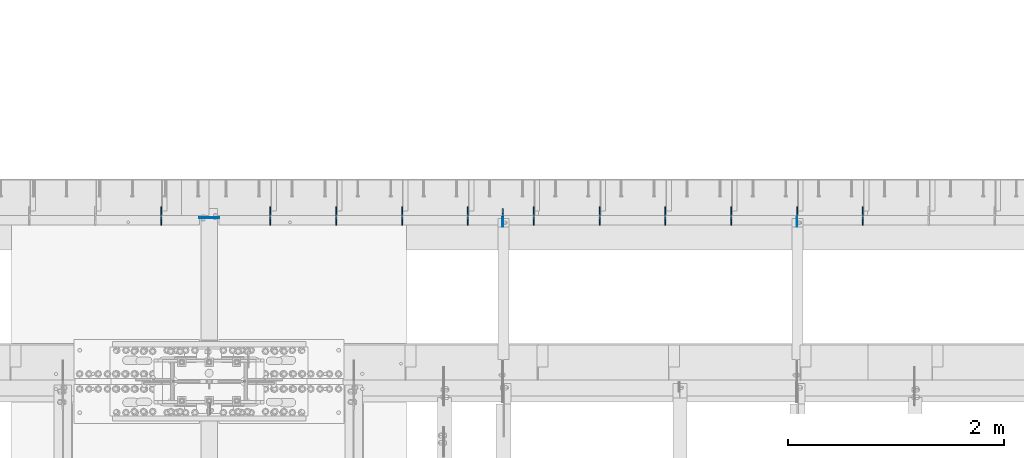
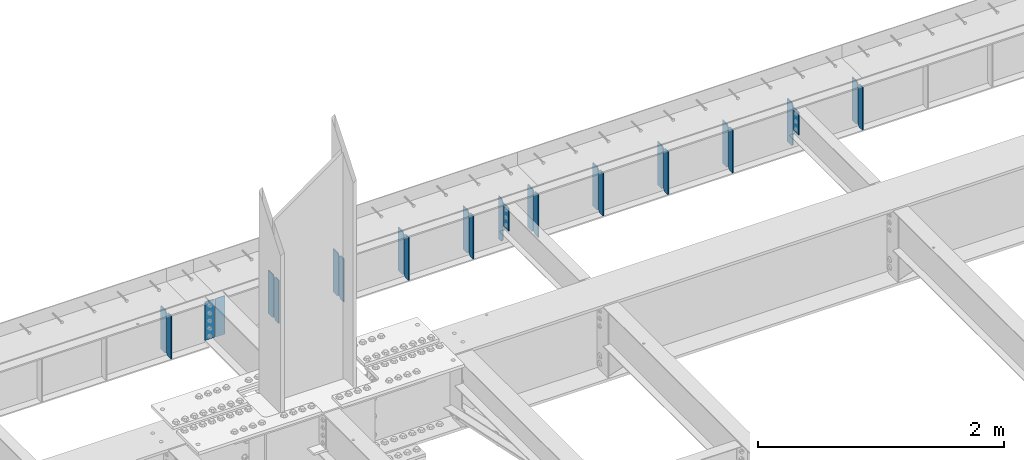
# One storey, part 1612 of 1763: 26 plates, 3 elements without a shape of their own.
"""IFC2X3 building model written with IfcOpenShell, lengths in millimetres."""

from ifc_helpers import new_model, si_unit, frame, origin_with_axes, place, context, subcontext, project, spatial, faceted_brep, material, type_object, element, aggregate, save


model = new_model("IFC2X3")

# Units and contexts
model_context = context("Model", 3, precision=1e-05, world=origin_with_axes())
body_context = subcontext(model_context, "Body", "Model", "MODEL_VIEW")
ifc_project = project(units=[si_unit("LENGTHUNIT", "METRE", prefix="MILLI"), si_unit("AREAUNIT", "SQUARE_METRE"), si_unit("VOLUMEUNIT", "CUBIC_METRE"), si_unit("MASSUNIT", "GRAM", prefix="KILO"), si_unit("TIMEUNIT", "SECOND"), si_unit("PLANEANGLEUNIT", "RADIAN"), si_unit("SOLIDANGLEUNIT", "STERADIAN"), si_unit("THERMODYNAMICTEMPERATUREUNIT", "DEGREE_CELSIUS"), si_unit("LUMINOUSINTENSITYUNIT", "LUMEN")], contexts=[model_context])

# Site, building, storey
site_placement = place(None, origin_with_axes())
site = spatial("IfcSite", under=ifc_project, at=site_placement, CompositionType="ELEMENT")
building_placement = place(site_placement, origin_with_axes())
building = spatial("IfcBuilding", under=site, at=building_placement, Name="Undefined", CompositionType="ELEMENT")
storey_placement = place(building_placement, origin_with_axes())
storey = spatial("IfcBuildingStorey", under=building, at=storey_placement, Name="Undefined", CompositionType="ELEMENT", Elevation=0.0)

# Assembly, plates
assembly_1_placement = place(storey_placement, origin_with_axes())
assembly_1 = element("IfcElementAssembly", 1, at=assembly_1_placement, inside=storey, Name="BEAM", AssemblyPlace="NOTDEFINED", PredefinedType="RIGID_FRAME")
ifc_material = material(Name="STEEL/A36")
plate_type_1 = type_object("IfcPlateType", PredefinedType="NOTDEFINED")
plate_1_placement = place(assembly_1_placement, frame((-66437.8997736984, 53568.6, 4752.975), z_axis=(0.0, 0.0, 1.0), x_axis=(0.0, 1.0, 0.0)))
plate_1 = element("IfcPlate", 2, at=plate_1_placement, type_object=plate_type_1, material=ifc_material, Name="PLATE", context=body_context, shape_type="Brep", body=[
    faceted_brep([(0.0, -4.76249999999982, 0.0), (0.0, -4.76249999999709, 428.625), (0.0, 4.76249999999709, 428.625), (0.0, 4.76249999999982, 0.0), (53.1812477111816, -4.76249999999709, 428.625), (53.1812477111816, 4.76249999999709, 428.625), (72.2312469482422, -4.76249999999709, 409.575000762939), (72.2312469482422, 4.76249999999709, 409.575000762939), (72.2312469482422, -4.76249999999709, 19.0499992370605), (72.2312469482422, 4.76249999999709, 19.0499992370605), (53.1812477111816, -4.76249999999709, 0.0), (53.1812477111816, 4.76249999999709, 0.0)], [[[0, 1, 2, 3]], [[1, 4, 5, 2]], [[4, 6, 7, 5]], [[6, 8, 9, 7]], [[8, 10, 11, 9]], [[10, 0, 3, 11]], [[5, 7, 9, 11, 3, 2]], [[10, 8, 6, 4, 1, 0]]]),
])
plate_2_placement = place(assembly_1_placement, frame((-67657.0997736984, 53568.6, 4752.975), z_axis=(0.0, 0.0, 1.0), x_axis=(0.0, 1.0, 0.0)))
plate_2 = element("IfcPlate", 3, at=plate_2_placement, type_object=plate_type_1, material=ifc_material, Name="PLATE", context=body_context, shape_type="Brep", body=[
    faceted_brep([(0.0, -4.76249999999982, 0.0), (0.0, -4.76249999999709, 428.625), (0.0, 4.76249999999709, 428.625), (0.0, 4.76249999999982, 0.0), (53.1812477111816, -4.76249999999709, 428.625), (53.1812477111816, 4.76249999999709, 428.625), (72.2312469482422, -4.76249999999709, 409.575000762939), (72.2312469482422, 4.76249999999709, 409.575000762939), (72.2312469482422, -4.76249999999709, 19.0499992370605), (72.2312469482422, 4.76249999999709, 19.0499992370605), (53.1812477111816, -4.76249999999709, 0.0), (53.1812477111816, 4.76249999999709, 0.0)], [[[0, 1, 2, 3]], [[1, 4, 5, 2]], [[4, 6, 7, 5]], [[6, 8, 9, 7]], [[8, 10, 11, 9]], [[10, 0, 3, 11]], [[5, 7, 9, 11, 3, 2]], [[10, 8, 6, 4, 1, 0]]]),
])
plate_3_placement = place(assembly_1_placement, frame((-68266.6997736983, 53568.6, 4752.975), z_axis=(0.0, 0.0, 1.0), x_axis=(0.0, 1.0, 0.0)))
plate_3 = element("IfcPlate", 4, at=plate_3_placement, type_object=plate_type_1, material=ifc_material, Name="PLATE", context=body_context, shape_type="Brep", body=[
    faceted_brep([(0.0, -4.76249999999982, 0.0), (0.0, -4.76249999999709, 428.625), (0.0, 4.76249999999709, 428.625), (0.0, 4.76249999999982, 0.0), (53.1812477111816, -4.76249999999709, 428.625), (53.1812477111816, 4.76249999999709, 428.625), (72.2312469482422, -4.76249999999709, 409.575000762939), (72.2312469482422, 4.76249999999709, 409.575000762939), (72.2312469482422, -4.76249999999709, 19.0499992370605), (72.2312469482422, 4.76249999999709, 19.0499992370605), (53.1812477111816, -4.76249999999709, 0.0), (53.1812477111816, 4.76249999999709, 0.0)], [[[0, 1, 2, 3]], [[1, 4, 5, 2]], [[4, 6, 7, 5]], [[6, 8, 9, 7]], [[8, 10, 11, 9]], [[10, 0, 3, 11]], [[5, 7, 9, 11, 3, 2]], [[10, 8, 6, 4, 1, 0]]]),
])
plate_4_placement = place(assembly_1_placement, frame((-68876.2997736984, 53568.6, 4752.975), z_axis=(0.0, 0.0, 1.0), x_axis=(0.0, 1.0, 0.0)))
plate_4 = element("IfcPlate", 5, at=plate_4_placement, type_object=plate_type_1, material=ifc_material, Name="PLATE", context=body_context, shape_type="Brep", body=[
    faceted_brep([(0.0, -4.76249999999982, 0.0), (0.0, -4.76249999999709, 428.625), (0.0, 4.76249999999709, 428.625), (0.0, 4.76249999999982, 0.0), (53.1812477111816, -4.76249999999709, 428.625), (53.1812477111816, 4.76249999999709, 428.625), (72.2312469482422, -4.76249999999709, 409.575000762939), (72.2312469482422, 4.76249999999709, 409.575000762939), (72.2312469482422, -4.76249999999709, 19.0499992370605), (72.2312469482422, 4.76249999999709, 19.0499992370605), (53.1812477111816, -4.76249999999709, 0.0), (53.1812477111816, 4.76249999999709, 0.0)], [[[0, 1, 2, 3]], [[1, 4, 5, 2]], [[4, 6, 7, 5]], [[6, 8, 9, 7]], [[8, 10, 11, 9]], [[10, 0, 3, 11]], [[5, 7, 9, 11, 3, 2]], [[10, 8, 6, 4, 1, 0]]]),
])
plate_5_placement = place(assembly_1_placement, frame((-69485.8997736984, 53568.6, 4752.975), z_axis=(0.0, 0.0, 1.0), x_axis=(0.0, 1.0, 0.0)))
plate_5 = element("IfcPlate", 6, at=plate_5_placement, type_object=plate_type_1, material=ifc_material, Name="PLATE", context=body_context, shape_type="Brep", body=[
    faceted_brep([(0.0, -4.76249999999982, 0.0), (0.0, -4.76249999999709, 428.625), (0.0, 4.76249999999709, 428.625), (0.0, 4.76249999999982, 0.0), (53.1812477111816, -4.76249999999709, 428.625), (53.1812477111816, 4.76249999999709, 428.625), (72.2312469482422, -4.76249999999709, 409.575000762939), (72.2312469482422, 4.76249999999709, 409.575000762939), (72.2312469482422, -4.76249999999709, 19.0499992370605), (72.2312469482422, 4.76249999999709, 19.0499992370605), (53.1812477111816, -4.76249999999709, 0.0), (53.1812477111816, 4.76249999999709, 0.0)], [[[0, 1, 2, 3]], [[1, 4, 5, 2]], [[4, 6, 7, 5]], [[6, 8, 9, 7]], [[8, 10, 11, 9]], [[10, 0, 3, 11]], [[5, 7, 9, 11, 3, 2]], [[10, 8, 6, 4, 1, 0]]]),
])
plate_6_placement = place(assembly_1_placement, frame((-70095.4997736983, 53568.6, 4752.975), z_axis=(0.0, 0.0, 1.0), x_axis=(0.0, 1.0, 0.0)))
plate_6 = element("IfcPlate", 7, at=plate_6_placement, type_object=plate_type_1, material=ifc_material, Name="PLATE", context=body_context, shape_type="Brep", body=[
    faceted_brep([(0.0, -4.76249999999982, 0.0), (0.0, -4.76249999999709, 428.625), (0.0, 4.76249999999709, 428.625), (0.0, 4.76249999999982, 0.0), (53.1812477111816, -4.76249999999709, 428.625), (53.1812477111816, 4.76249999999709, 428.625), (72.2312469482422, -4.76249999999709, 409.575000762939), (72.2312469482422, 4.76249999999709, 409.575000762939), (72.2312469482422, -4.76249999999709, 19.0499992370605), (72.2312469482422, 4.76249999999709, 19.0499992370605), (53.1812477111816, -4.76249999999709, 0.0), (53.1812477111816, 4.76249999999709, 0.0)], [[[0, 1, 2, 3]], [[1, 4, 5, 2]], [[4, 6, 7, 5]], [[6, 8, 9, 7]], [[8, 10, 11, 9]], [[10, 0, 3, 11]], [[5, 7, 9, 11, 3, 2]], [[10, 8, 6, 4, 1, 0]]]),
])
plate_7_placement = place(assembly_1_placement, frame((-70705.0997736984, 53568.6, 4752.975), z_axis=(0.0, 0.0, 1.0), x_axis=(0.0, 1.0, 0.0)))
plate_7 = element("IfcPlate", 8, at=plate_7_placement, type_object=plate_type_1, material=ifc_material, Name="PLATE", context=body_context, shape_type="Brep", body=[
    faceted_brep([(0.0, -4.76249999999982, 0.0), (0.0, -4.76249999999709, 428.625), (0.0, 4.76249999999709, 428.625), (0.0, 4.76249999999982, 0.0), (53.1812477111816, -4.76249999999709, 428.625), (53.1812477111816, 4.76249999999709, 428.625), (72.2312469482422, -4.76249999999709, 409.575000762939), (72.2312469482422, 4.76249999999709, 409.575000762939), (72.2312469482422, -4.76249999999709, 19.0499992370605), (72.2312469482422, 4.76249999999709, 19.0499992370605), (53.1812477111816, -4.76249999999709, 0.0), (53.1812477111816, 4.76249999999709, 0.0)], [[[0, 1, 2, 3]], [[1, 4, 5, 2]], [[4, 6, 7, 5]], [[6, 8, 9, 7]], [[8, 10, 11, 9]], [[10, 0, 3, 11]], [[5, 7, 9, 11, 3, 2]], [[10, 8, 6, 4, 1, 0]]]),
])
plate_8_placement = place(assembly_1_placement, frame((-71314.6997736983, 53568.6, 4752.975), z_axis=(0.0, 0.0, 1.0), x_axis=(0.0, 1.0, 0.0)))
plate_8 = element("IfcPlate", 9, at=plate_8_placement, type_object=plate_type_1, material=ifc_material, Name="PLATE", context=body_context, shape_type="Brep", body=[
    faceted_brep([(0.0, -4.76249999999982, 0.0), (0.0, -4.76249999999709, 428.625), (0.0, 4.76249999999709, 428.625), (0.0, 4.76249999999982, 0.0), (53.1812477111816, -4.76249999999709, 428.625), (53.1812477111816, 4.76249999999709, 428.625), (72.2312469482422, -4.76249999999709, 409.575000762939), (72.2312469482422, 4.76249999999709, 409.575000762939), (72.2312469482422, -4.76249999999709, 19.0499992370605), (72.2312469482422, 4.76249999999709, 19.0499992370605), (53.1812477111816, -4.76249999999709, 0.0), (53.1812477111816, 4.76249999999709, 0.0)], [[[0, 1, 2, 3]], [[1, 4, 5, 2]], [[4, 6, 7, 5]], [[6, 8, 9, 7]], [[8, 10, 11, 9]], [[10, 0, 3, 11]], [[5, 7, 9, 11, 3, 2]], [[10, 8, 6, 4, 1, 0]]]),
])
plate_9_placement = place(assembly_1_placement, frame((-71924.2997736984, 53568.6, 4752.975), z_axis=(0.0, 0.0, 1.0), x_axis=(0.0, 1.0, 0.0)))
plate_9 = element("IfcPlate", 10, at=plate_9_placement, type_object=plate_type_1, material=ifc_material, Name="PLATE", context=body_context, shape_type="Brep", body=[
    faceted_brep([(0.0, -4.76249999999982, 0.0), (0.0, -4.76249999999709, 428.625), (0.0, 4.76249999999709, 428.625), (0.0, 4.76249999999982, 0.0), (53.1812477111816, -4.76249999999709, 428.625), (53.1812477111816, 4.76249999999709, 428.625), (72.2312469482422, -4.76249999999709, 409.575000762939), (72.2312469482422, 4.76249999999709, 409.575000762939), (72.2312469482422, -4.76249999999709, 19.0499992370605), (72.2312469482422, 4.76249999999709, 19.0499992370605), (53.1812477111816, -4.76249999999709, 0.0), (53.1812477111816, 4.76249999999709, 0.0)], [[[0, 1, 2, 3]], [[1, 4, 5, 2]], [[4, 6, 7, 5]], [[6, 8, 9, 7]], [[8, 10, 11, 9]], [[10, 0, 3, 11]], [[5, 7, 9, 11, 3, 2]], [[10, 8, 6, 4, 1, 0]]]),
])

# Assembly, plate
assembly_2_placement = place(storey_placement, origin_with_axes())
assembly_2 = element("IfcElementAssembly", 11, at=assembly_2_placement, inside=storey, Name="BEAM", AssemblyPlace="NOTDEFINED", PredefinedType="RIGID_FRAME")
plate_10_placement = place(assembly_2_placement, frame((-72935.9341486983, 53568.6, 4752.975), z_axis=(0.0, 0.0, 1.0), x_axis=(0.0, 1.0, 0.0)))
plate_10 = element("IfcPlate", 12, at=plate_10_placement, type_object=plate_type_1, material=ifc_material, Name="PLATE", context=body_context, shape_type="Brep", body=[
    faceted_brep([(0.0, -4.76249999999982, 0.0), (0.0, -4.76249999999709, 428.625), (0.0, 4.76249999999709, 428.625), (0.0, 4.76249999999982, 0.0), (53.1812477111816, -4.76249999999709, 428.625), (53.1812477111816, 4.76249999999709, 428.625), (72.2312469482422, -4.76249999999709, 409.575000762939), (72.2312469482422, 4.76249999999709, 409.575000762939), (72.2312469482422, -4.76249999999709, 19.0499992370605), (72.2312469482422, 4.76249999999709, 19.0499992370605), (53.1812477111816, -4.76249999999709, 0.0), (53.1812477111816, 4.76249999999709, 0.0)], [[[0, 1, 2, 3]], [[1, 4, 5, 2]], [[4, 6, 7, 5]], [[6, 8, 9, 7]], [[8, 10, 11, 9]], [[10, 0, 3, 11]], [[5, 7, 9, 11, 3, 2]], [[10, 8, 6, 4, 1, 0]]]),
])

# Plate
plate_type_2 = type_object("IfcPlateType", PredefinedType="NOTDEFINED")
plate_11_placement = place(assembly_1_placement, frame((-66437.8997736984, 53648.76875, 4752.975), z_axis=(0.0, 0.0, 1.0), x_axis=(0.0, 1.0, 0.0)))
plate_11 = element("IfcPlate", 13, at=plate_11_placement, type_object=plate_type_2, material=ifc_material, Name="PLATE", context=body_context, shape_type="Brep", body=[
    faceted_brep([(6.96272763889283e-08, -4.76249999999709, 19.0499992370605), (0.0, -4.76249999999709, 409.575000762939), (0.0, 4.76249999999709, 409.575000762939), (6.96454662829638e-08, 4.76249999999709, 19.0499992370605), (19.0499992370605, -4.76249999999709, 428.625), (19.0499992370605, 4.76249999999709, 428.625), (89.6937484741211, -4.76249999999709, 428.625), (89.6937484741211, 4.76249999999709, 428.625), (89.6937484741211, -4.76249999999709, 0.0), (89.6937484741211, 4.76249999999709, 0.0), (19.0499992370533, -4.76249999996799, -2.09183781407773e-11), (19.0499992370678, 4.76250000003347, -2.09183781407773e-11)], [[[0, 1, 2, 3]], [[1, 4, 5, 2]], [[4, 6, 7, 5]], [[6, 8, 9, 7]], [[8, 10, 11, 9]], [[10, 0, 3, 11]], [[5, 7, 9, 11, 3, 2]], [[10, 8, 6, 4, 1, 0]]]),
])

plate_12_placement = place(assembly_1_placement, frame((-67047.4997736983, 53648.76875, 4752.975), z_axis=(0.0, 0.0, 1.0), x_axis=(0.0, 1.0, 0.0)))
plate_12 = element("IfcPlate", 14, at=plate_12_placement, type_object=plate_type_2, material=ifc_material, Name="PLATE", context=body_context, shape_type="Brep", body=[
    faceted_brep([(6.96272763889283e-08, -4.76249999999709, 19.0499992370605), (0.0, -4.76249999999709, 409.575000762939), (0.0, 4.76249999999709, 409.575000762939), (6.96454662829638e-08, 4.76249999999709, 19.0499992370605), (19.0499992370605, -4.76249999999709, 428.625), (19.0499992370605, 4.76249999999709, 428.625), (89.6937484741211, -4.76249999999709, 428.625), (89.6937484741211, 4.76249999999709, 428.625), (89.6937484741211, -4.76249999999709, 0.0), (89.6937484741211, 4.76249999999709, 0.0), (19.0499992370533, -4.76249999996799, -2.09183781407773e-11), (19.0499992370678, 4.76250000003347, -2.09183781407773e-11)], [[[0, 1, 2, 3]], [[1, 4, 5, 2]], [[4, 6, 7, 5]], [[6, 8, 9, 7]], [[8, 10, 11, 9]], [[10, 0, 3, 11]], [[5, 7, 9, 11, 3, 2]], [[10, 8, 6, 4, 1, 0]]]),
])

plate_13_placement = place(assembly_1_placement, frame((-67657.0997736984, 53648.76875, 4752.975), z_axis=(0.0, 0.0, 1.0), x_axis=(0.0, 1.0, 0.0)))
plate_13 = element("IfcPlate", 15, at=plate_13_placement, type_object=plate_type_2, material=ifc_material, Name="PLATE", context=body_context, shape_type="Brep", body=[
    faceted_brep([(6.96272763889283e-08, -4.76249999999709, 19.0499992370605), (0.0, -4.76249999999709, 409.575000762939), (0.0, 4.76249999999709, 409.575000762939), (6.96454662829638e-08, 4.76249999999709, 19.0499992370605), (19.0499992370605, -4.76249999999709, 428.625), (19.0499992370605, 4.76249999999709, 428.625), (89.6937484741211, -4.76249999999709, 428.625), (89.6937484741211, 4.76249999999709, 428.625), (89.6937484741211, -4.76249999999709, 0.0), (89.6937484741211, 4.76249999999709, 0.0), (19.0499992370533, -4.76249999996799, -2.09183781407773e-11), (19.0499992370678, 4.76250000003347, -2.09183781407773e-11)], [[[0, 1, 2, 3]], [[1, 4, 5, 2]], [[4, 6, 7, 5]], [[6, 8, 9, 7]], [[8, 10, 11, 9]], [[10, 0, 3, 11]], [[5, 7, 9, 11, 3, 2]], [[10, 8, 6, 4, 1, 0]]]),
])

plate_14_placement = place(assembly_1_placement, frame((-68266.6997736983, 53648.76875, 4752.975), z_axis=(0.0, 0.0, 1.0), x_axis=(0.0, 1.0, 0.0)))
plate_14 = element("IfcPlate", 16, at=plate_14_placement, type_object=plate_type_2, material=ifc_material, Name="PLATE", context=body_context, shape_type="Brep", body=[
    faceted_brep([(6.96272763889283e-08, -4.76249999999709, 19.0499992370605), (0.0, -4.76249999999709, 409.575000762939), (0.0, 4.76249999999709, 409.575000762939), (6.96454662829638e-08, 4.76249999999709, 19.0499992370605), (19.0499992370605, -4.76249999999709, 428.625), (19.0499992370605, 4.76249999999709, 428.625), (89.6937484741211, -4.76249999999709, 428.625), (89.6937484741211, 4.76249999999709, 428.625), (89.6937484741211, -4.76249999999709, 0.0), (89.6937484741211, 4.76249999999709, 0.0), (19.0499992370533, -4.76249999996799, -2.09183781407773e-11), (19.0499992370678, 4.76250000003347, -2.09183781407773e-11)], [[[0, 1, 2, 3]], [[1, 4, 5, 2]], [[4, 6, 7, 5]], [[6, 8, 9, 7]], [[8, 10, 11, 9]], [[10, 0, 3, 11]], [[5, 7, 9, 11, 3, 2]], [[10, 8, 6, 4, 1, 0]]]),
])

plate_15_placement = place(assembly_1_placement, frame((-68876.2997736984, 53648.76875, 4752.975), z_axis=(0.0, 0.0, 1.0), x_axis=(0.0, 1.0, 0.0)))
plate_15 = element("IfcPlate", 17, at=plate_15_placement, type_object=plate_type_2, material=ifc_material, Name="PLATE", context=body_context, shape_type="Brep", body=[
    faceted_brep([(6.96272763889283e-08, -4.76249999999709, 19.0499992370605), (0.0, -4.76249999999709, 409.575000762939), (0.0, 4.76249999999709, 409.575000762939), (6.96454662829638e-08, 4.76249999999709, 19.0499992370605), (19.0499992370605, -4.76249999999709, 428.625), (19.0499992370605, 4.76249999999709, 428.625), (89.6937484741211, -4.76249999999709, 428.625), (89.6937484741211, 4.76249999999709, 428.625), (89.6937484741211, -4.76249999999709, 0.0), (89.6937484741211, 4.76249999999709, 0.0), (19.0499992370533, -4.76249999996799, -2.09183781407773e-11), (19.0499992370678, 4.76250000003347, -2.09183781407773e-11)], [[[0, 1, 2, 3]], [[1, 4, 5, 2]], [[4, 6, 7, 5]], [[6, 8, 9, 7]], [[8, 10, 11, 9]], [[10, 0, 3, 11]], [[5, 7, 9, 11, 3, 2]], [[10, 8, 6, 4, 1, 0]]]),
])

plate_16_placement = place(assembly_1_placement, frame((-69485.8997736984, 53648.76875, 4752.975), z_axis=(0.0, 0.0, 1.0), x_axis=(0.0, 1.0, 0.0)))
plate_16 = element("IfcPlate", 18, at=plate_16_placement, type_object=plate_type_2, material=ifc_material, Name="PLATE", context=body_context, shape_type="Brep", body=[
    faceted_brep([(6.96272763889283e-08, -4.76249999999709, 19.0499992370605), (0.0, -4.76249999999709, 409.575000762939), (0.0, 4.76249999999709, 409.575000762939), (6.96454662829638e-08, 4.76249999999709, 19.0499992370605), (19.0499992370605, -4.76249999999709, 428.625), (19.0499992370605, 4.76249999999709, 428.625), (89.6937484741211, -4.76249999999709, 428.625), (89.6937484741211, 4.76249999999709, 428.625), (89.6937484741211, -4.76249999999709, 0.0), (89.6937484741211, 4.76249999999709, 0.0), (19.0499992370533, -4.76249999996799, -2.09183781407773e-11), (19.0499992370678, 4.76250000003347, -2.09183781407773e-11)], [[[0, 1, 2, 3]], [[1, 4, 5, 2]], [[4, 6, 7, 5]], [[6, 8, 9, 7]], [[8, 10, 11, 9]], [[10, 0, 3, 11]], [[5, 7, 9, 11, 3, 2]], [[10, 8, 6, 4, 1, 0]]]),
])

plate_17_placement = place(assembly_1_placement, frame((-70095.4997736983, 53648.76875, 4752.975), z_axis=(0.0, 0.0, 1.0), x_axis=(0.0, 1.0, 0.0)))
plate_17 = element("IfcPlate", 19, at=plate_17_placement, type_object=plate_type_2, material=ifc_material, Name="PLATE", context=body_context, shape_type="Brep", body=[
    faceted_brep([(6.96272763889283e-08, -4.76249999999709, 19.0499992370605), (0.0, -4.76249999999709, 409.575000762939), (0.0, 4.76249999999709, 409.575000762939), (6.96454662829638e-08, 4.76249999999709, 19.0499992370605), (19.0499992370605, -4.76249999999709, 428.625), (19.0499992370605, 4.76249999999709, 428.625), (89.6937484741211, -4.76249999999709, 428.625), (89.6937484741211, 4.76249999999709, 428.625), (89.6937484741211, -4.76249999999709, 0.0), (89.6937484741211, 4.76249999999709, 0.0), (19.0499992370533, -4.76249999996799, -2.09183781407773e-11), (19.0499992370678, 4.76250000003347, -2.09183781407773e-11)], [[[0, 1, 2, 3]], [[1, 4, 5, 2]], [[4, 6, 7, 5]], [[6, 8, 9, 7]], [[8, 10, 11, 9]], [[10, 0, 3, 11]], [[5, 7, 9, 11, 3, 2]], [[10, 8, 6, 4, 1, 0]]]),
])

plate_18_placement = place(assembly_1_placement, frame((-70705.0997736984, 53648.76875, 4752.975), z_axis=(0.0, 0.0, 1.0), x_axis=(0.0, 1.0, 0.0)))
plate_18 = element("IfcPlate", 20, at=plate_18_placement, type_object=plate_type_2, material=ifc_material, Name="PLATE", context=body_context, shape_type="Brep", body=[
    faceted_brep([(6.96272763889283e-08, -4.76249999999709, 19.0499992370605), (0.0, -4.76249999999709, 409.575000762939), (0.0, 4.76249999999709, 409.575000762939), (6.96454662829638e-08, 4.76249999999709, 19.0499992370605), (19.0499992370605, -4.76249999999709, 428.625), (19.0499992370605, 4.76249999999709, 428.625), (89.6937484741211, -4.76249999999709, 428.625), (89.6937484741211, 4.76249999999709, 428.625), (89.6937484741211, -4.76249999999709, 0.0), (89.6937484741211, 4.76249999999709, 0.0), (19.0499992370533, -4.76249999996799, -2.09183781407773e-11), (19.0499992370678, 4.76250000003347, -2.09183781407773e-11)], [[[0, 1, 2, 3]], [[1, 4, 5, 2]], [[4, 6, 7, 5]], [[6, 8, 9, 7]], [[8, 10, 11, 9]], [[10, 0, 3, 11]], [[5, 7, 9, 11, 3, 2]], [[10, 8, 6, 4, 1, 0]]]),
])

plate_19_placement = place(assembly_1_placement, frame((-71314.6997736983, 53648.76875, 4752.975), z_axis=(0.0, 0.0, 1.0), x_axis=(0.0, 1.0, 0.0)))
plate_19 = element("IfcPlate", 21, at=plate_19_placement, type_object=plate_type_2, material=ifc_material, Name="PLATE", context=body_context, shape_type="Brep", body=[
    faceted_brep([(6.96272763889283e-08, -4.76249999999709, 19.0499992370605), (0.0, -4.76249999999709, 409.575000762939), (0.0, 4.76249999999709, 409.575000762939), (6.96454662829638e-08, 4.76249999999709, 19.0499992370605), (19.0499992370605, -4.76249999999709, 428.625), (19.0499992370605, 4.76249999999709, 428.625), (89.6937484741211, -4.76249999999709, 428.625), (89.6937484741211, 4.76249999999709, 428.625), (89.6937484741211, -4.76249999999709, 0.0), (89.6937484741211, 4.76249999999709, 0.0), (19.0499992370533, -4.76249999996799, -2.09183781407773e-11), (19.0499992370678, 4.76250000003347, -2.09183781407773e-11)], [[[0, 1, 2, 3]], [[1, 4, 5, 2]], [[4, 6, 7, 5]], [[6, 8, 9, 7]], [[8, 10, 11, 9]], [[10, 0, 3, 11]], [[5, 7, 9, 11, 3, 2]], [[10, 8, 6, 4, 1, 0]]]),
])

plate_20_placement = place(assembly_1_placement, frame((-71924.2997736984, 53648.76875, 4752.975), z_axis=(0.0, 0.0, 1.0), x_axis=(0.0, 1.0, 0.0)))
plate_20 = element("IfcPlate", 22, at=plate_20_placement, type_object=plate_type_2, material=ifc_material, Name="PLATE", context=body_context, shape_type="Brep", body=[
    faceted_brep([(6.96272763889283e-08, -4.76249999999709, 19.0499992370605), (0.0, -4.76249999999709, 409.575000762939), (0.0, 4.76249999999709, 409.575000762939), (6.96454662829638e-08, 4.76249999999709, 19.0499992370605), (19.0499992370605, -4.76249999999709, 428.625), (19.0499992370605, 4.76249999999709, 428.625), (89.6937484741211, -4.76249999999709, 428.625), (89.6937484741211, 4.76249999999709, 428.625), (89.6937484741211, -4.76249999999709, 0.0), (89.6937484741211, 4.76249999999709, 0.0), (19.0499992370533, -4.76249999996799, -2.09183781407773e-11), (19.0499992370678, 4.76250000003347, -2.09183781407773e-11)], [[[0, 1, 2, 3]], [[1, 4, 5, 2]], [[4, 6, 7, 5]], [[6, 8, 9, 7]], [[8, 10, 11, 9]], [[10, 0, 3, 11]], [[5, 7, 9, 11, 3, 2]], [[10, 8, 6, 4, 1, 0]]]),
])

plate_21_placement = place(assembly_2_placement, frame((-72935.9341486983, 53648.76875, 4752.975), z_axis=(0.0, 0.0, 1.0), x_axis=(0.0, 1.0, 0.0)))
plate_21 = element("IfcPlate", 23, at=plate_21_placement, type_object=plate_type_2, material=ifc_material, Name="PLATE", context=body_context, shape_type="Brep", body=[
    faceted_brep([(6.96272763889283e-08, -4.76249999999709, 19.0499992370605), (0.0, -4.76249999999709, 409.575000762939), (0.0, 4.76249999999709, 409.575000762939), (6.96454662829638e-08, 4.76249999999709, 19.0499992370605), (19.0499992370605, -4.76249999999709, 428.625), (19.0499992370605, 4.76249999999709, 428.625), (89.6937484741211, -4.76249999999709, 428.625), (89.6937484741211, 4.76249999999709, 428.625), (89.6937484741211, -4.76249999999709, 0.0), (89.6937484741211, 4.76249999999709, 0.0), (19.0499992370533, -4.76249999996799, -2.09183781407773e-11), (19.0499992370678, 4.76250000003347, -2.09183781407773e-11)], [[[0, 1, 2, 3]], [[1, 4, 5, 2]], [[4, 6, 7, 5]], [[6, 8, 9, 7]], [[8, 10, 11, 9]], [[10, 0, 3, 11]], [[5, 7, 9, 11, 3, 2]], [[10, 8, 6, 4, 1, 0]]]),
])

aggregate(assembly_2, [plate_10, plate_21])

plate_type_3 = type_object("IfcPlateType", PredefinedType="NOTDEFINED")
plate_22_placement = place(assembly_1_placement, frame((-67049.0872736984, 53640.83125, 5156.2), z_axis=(0.0, -1.0, 0.0), x_axis=(0.0, 0.0, -1.0)))
plate_22 = element("IfcPlate", 24, at=plate_22_placement, type_object=plate_type_3, material=ifc_material, Name="PLATE", context=body_context, shape_type="Brep", body=[
    faceted_brep([(1.81898940354586e-12, -3.17500000000291, 0.0), (0.0, -3.17499999999927, 88.9000015258789), (0.0, 3.17499999999927, 88.9000015258789), (-1.81898940354586e-12, 3.17499999997381, 0.0), (228.600006103516, -3.17499999999927, 88.9000015258789), (228.600006103516, 3.17499999999927, 88.9000015258789), (228.600006103516, -3.17500000001019, -7.27595761418343e-12), (228.600006103516, 3.17499999999563, -7.27595761418343e-12)], [[[0, 1, 2, 3]], [[1, 4, 5, 2]], [[4, 6, 7, 5]], [[6, 0, 3, 7]], [[5, 7, 3, 2]], [[6, 4, 1, 0]]]),
])

plate_23_placement = place(assembly_1_placement, frame((-69773.2372736984, 53640.83125, 5156.2), z_axis=(0.0, -1.0, 0.0), x_axis=(0.0, 0.0, -1.0)))
plate_23 = element("IfcPlate", 25, at=plate_23_placement, type_object=plate_type_3, material=ifc_material, Name="PLATE", context=body_context, shape_type="Brep", body=[
    faceted_brep([(1.81898940354586e-12, -3.17500000000291, 0.0), (0.0, -3.17499999999927, 88.9000015258789), (0.0, 3.17499999999927, 88.9000015258789), (-1.81898940354586e-12, 3.17499999997381, 0.0), (228.600006103516, -3.17499999999927, 88.9000015258789), (228.600006103516, 3.17499999999927, 88.9000015258789), (228.600006103516, -3.17500000001019, -7.27595761418343e-12), (228.600006103516, 3.17499999999563, -7.27595761418343e-12)], [[[0, 1, 2, 3]], [[1, 4, 5, 2]], [[4, 6, 7, 5]], [[6, 0, 3, 7]], [[5, 7, 3, 2]], [[6, 4, 1, 0]]]),
])

plate_type_4 = type_object("IfcPlateType", PredefinedType="NOTDEFINED")
plate_24_placement = place(assembly_1_placement, frame((-69773.237273746, 53648.76875, 4754.5625), z_axis=(0.0, 0.0, 1.0), x_axis=(0.0, 1.0, 0.0)))
plate_24 = element("IfcPlate", 26, at=plate_24_placement, type_object=plate_type_4, material=ifc_material, Name="PLATE", context=body_context, shape_type="Brep", body=[
    faceted_brep([(0.0, -3.17499999987194, 25.4000000001051), (0.0, -3.17500000000291, 400.050012588501), (0.0, 3.17500000000291, 400.050012588501), (0.0, 3.17500000014843, 25.4000000001197), (25.3999996185303, -3.17500000000291, 425.450012207031), (25.3999996185303, 3.17500000000291, 425.450012207031), (69.8499984741211, -3.17500000000291, 425.450012207031), (69.8499984741211, 3.17500000000291, 425.450012207031), (69.8499984741211, -3.17500000000291, 0.0), (69.8499984741211, 3.17500000000291, 0.0), (25.3999996184939, -3.17499999996653, 1.2732925824821e-11), (25.3999996185303, 3.17499995230901, 0.0)], [[[0, 1, 2, 3]], [[1, 4, 5, 2]], [[4, 6, 7, 5]], [[6, 8, 9, 7]], [[8, 10, 11, 9]], [[10, 0, 3, 11]], [[5, 7, 9, 11, 3, 2]], [[10, 8, 6, 4, 1, 0]]]),
])

aggregate(assembly_1, [plate_1, plate_11, plate_12, plate_2, plate_13, plate_3, plate_14, plate_4, plate_15, plate_5, plate_16, plate_6, plate_17, plate_7, plate_18, plate_8, plate_19, plate_9, plate_20, plate_22, plate_24, plate_23])

# Assembly, plates
assembly_3_placement = place(storey_placement, origin_with_axes())
assembly_3 = element("IfcElementAssembly", 27, at=assembly_3_placement, inside=storey, Name="BEAM", AssemblyPlace="NOTDEFINED", PredefinedType="RIGID_FRAME")
plate_type_5 = type_object("IfcPlateType", PredefinedType="NOTDEFINED")
plate_25_placement = place(assembly_3_placement, frame((-72487.0685236984, 53636.86225, 5156.2), z_axis=(1.0, 0.0, 0.0), x_axis=(0.0, 0.0, -1.0)))
plate_25 = element("IfcPlate", 28, at=plate_25_placement, type_object=plate_type_5, material=ifc_material, Name="PLATE", context=body_context, shape_type="Brep", body=[
    faceted_brep([(0.0, -3.96900000000096, 0.0), (0.0, -3.96899999999732, 88.9000015258789), (0.0, 3.96899999999732, 88.9000015258789), (0.0, 3.96900000000096, 0.0), (381.0, -3.96899999999732, 88.9000015258789), (381.0, 3.96899999999732, 88.9000015258789), (381.0, -3.96900000001915, 3.34694050252438e-10), (381.0, 3.9690000000046, 3.20142135024071e-10)], [[[0, 1, 2, 3]], [[1, 4, 5, 2]], [[4, 6, 7, 5]], [[6, 0, 3, 7]], [[5, 7, 3, 2]], [[6, 4, 1, 0]]]),
])
plate_26_placement = place(assembly_3_placement, frame((-72495.0060236984, 53636.86225, 5156.2), z_axis=(-1.0, 0.0, 0.0), x_axis=(0.0, 0.0, -1.0)))
plate_26 = element("IfcPlate", 29, at=plate_26_placement, type_object=plate_type_5, material=ifc_material, Name="PLATE", context=body_context, shape_type="Brep", body=[
    faceted_brep([(0.0, -3.96900000000096, 0.0), (0.0, -3.96899999999732, 88.9000015258789), (0.0, 3.96899999999732, 88.9000015258789), (0.0, 3.96900000000096, 0.0), (381.0, -3.96899999999732, 88.9000015258789), (381.0, 3.96899999999732, 88.9000015258789), (381.0, -3.96900000001915, 3.34694050252438e-10), (381.0, 3.9690000000046, 3.20142135024071e-10)], [[[0, 1, 2, 3]], [[1, 4, 5, 2]], [[4, 6, 7, 5]], [[6, 0, 3, 7]], [[5, 7, 3, 2]], [[6, 4, 1, 0]]]),
])
aggregate(assembly_3, [plate_25, plate_26])

save(model, "model.ifc")
